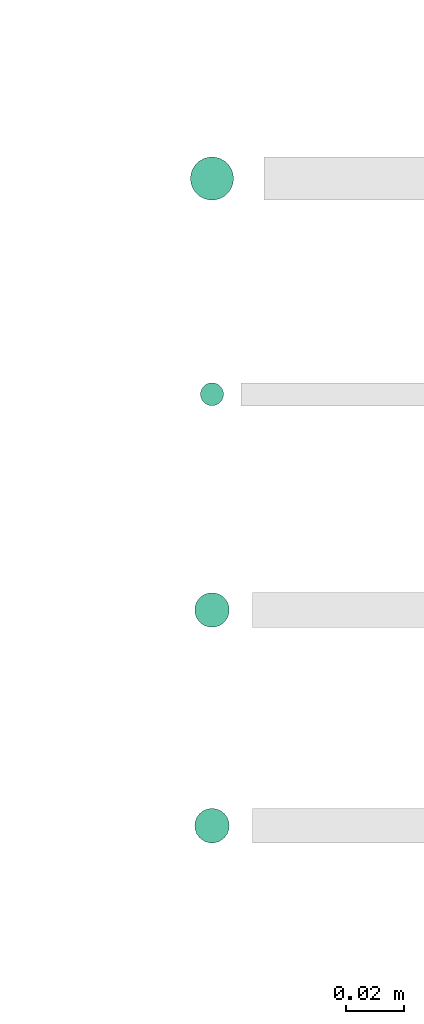
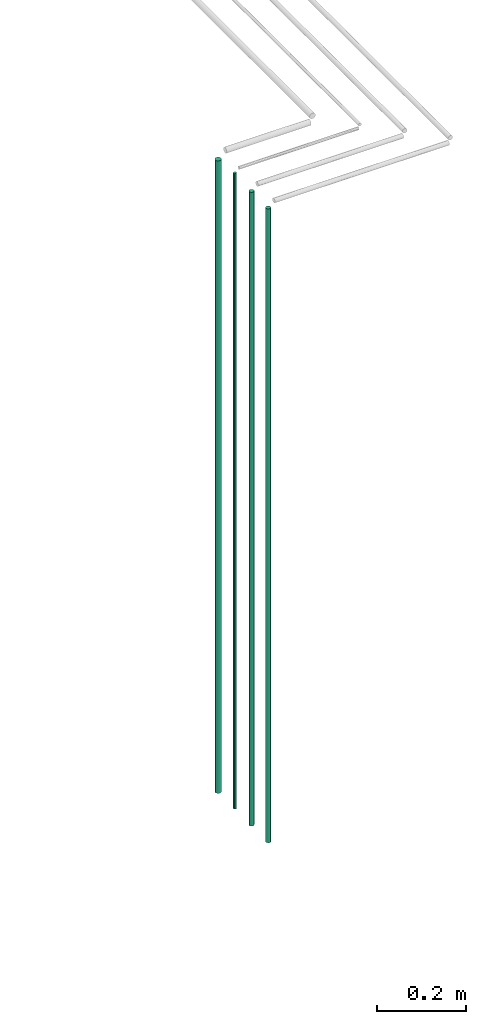
# One storey, part 10 of 65: 4 flow segments.
"""IFC2X3 building model written with IfcOpenShell, lengths in millimetres."""

from ifc_helpers import new_model, entity, si_unit, converted_unit, derived_unit, direction, frame, frame_2d, origin, origin_2d_with_axis, place, context, subcontext, project, spatial, circle, extrude, type_object, element, save


model = new_model("IFC2X3")

# Units and contexts
model_context = context("Model", 3, precision=0.01, world=origin(), true_north=direction((6.12303176911189e-17, 1.0)))
body_context = subcontext(model_context, "Body", "Model", "MODEL_VIEW")
ifc_project = project(units=[si_unit("LENGTHUNIT", "METRE", prefix="MILLI"), si_unit("AREAUNIT", "SQUARE_METRE"), si_unit("VOLUMEUNIT", "CUBIC_METRE"), converted_unit("PLANEANGLEUNIT", "DEGREE", entity("IfcRatioMeasure", 0.0174532925199433), si_unit("PLANEANGLEUNIT", "RADIAN"), dimensions=[0, 0, 0, 0, 0, 0, 0]), si_unit("MASSUNIT", "GRAM", prefix="KILO"), derived_unit("MASSDENSITYUNIT", [(si_unit("MASSUNIT", "GRAM", prefix="KILO"), 1), (si_unit("LENGTHUNIT", "METRE"), -3)]), derived_unit("MOMENTOFINERTIAUNIT", [(si_unit("LENGTHUNIT", "METRE"), 4)]), si_unit("TIMEUNIT", "SECOND"), si_unit("FREQUENCYUNIT", "HERTZ"), si_unit("THERMODYNAMICTEMPERATUREUNIT", "DEGREE_CELSIUS"), derived_unit("THERMALTRANSMITTANCEUNIT", [(si_unit("MASSUNIT", "GRAM", prefix="KILO"), 1), (si_unit("THERMODYNAMICTEMPERATUREUNIT", "KELVIN"), -1), (si_unit("TIMEUNIT", "SECOND"), -3)]), derived_unit("VOLUMETRICFLOWRATEUNIT", [(si_unit("LENGTHUNIT", "METRE"), 3), (si_unit("TIMEUNIT", "SECOND"), -1)]), derived_unit("MASSFLOWRATEUNIT", [(si_unit("MASSUNIT", "GRAM", prefix="KILO"), 1), (si_unit("TIMEUNIT", "SECOND"), -1)]), derived_unit("ROTATIONALFREQUENCYUNIT", [(si_unit("TIMEUNIT", "SECOND"), -1)]), si_unit("ELECTRICCURRENTUNIT", "AMPERE"), si_unit("ELECTRICVOLTAGEUNIT", "VOLT"), si_unit("POWERUNIT", "WATT"), si_unit("FORCEUNIT", "NEWTON", prefix="KILO"), si_unit("ILLUMINANCEUNIT", "LUX"), si_unit("LUMINOUSFLUXUNIT", "LUMEN"), si_unit("LUMINOUSINTENSITYUNIT", "CANDELA"), derived_unit("USERDEFINED", [(si_unit("MASSUNIT", "GRAM", prefix="KILO"), -1), (si_unit("LENGTHUNIT", "METRE"), -2), (si_unit("TIMEUNIT", "SECOND"), 3), (si_unit("LUMINOUSFLUXUNIT", "LUMEN"), 1)]), derived_unit("LINEARVELOCITYUNIT", [(si_unit("LENGTHUNIT", "METRE"), 1), (si_unit("TIMEUNIT", "SECOND"), -1)]), si_unit("PRESSUREUNIT", "PASCAL"), derived_unit("USERDEFINED", [(si_unit("LENGTHUNIT", "METRE"), -2), (si_unit("MASSUNIT", "GRAM", prefix="KILO"), 1), (si_unit("TIMEUNIT", "SECOND"), -2)]), derived_unit("LINEARFORCEUNIT", [(si_unit("MASSUNIT", "GRAM", prefix="KILO"), 1), (si_unit("LENGTHUNIT", "METRE"), 1), (si_unit("TIMEUNIT", "SECOND"), -2), (si_unit("LENGTHUNIT", "METRE"), -1)]), derived_unit("PLANARFORCEUNIT", [(si_unit("MASSUNIT", "GRAM", prefix="KILO"), 1), (si_unit("LENGTHUNIT", "METRE"), 1), (si_unit("TIMEUNIT", "SECOND"), -2), (si_unit("LENGTHUNIT", "METRE"), -2)])], contexts=[model_context])

# Site, building, storey
site_placement = place(None, frame((0.0, -0.00077364408347762, 0.0)))
site = spatial("IfcSite", under=ifc_project, at=site_placement, CompositionType="ELEMENT")
building_placement = place(site_placement, origin())
building = spatial("IfcBuilding", under=site, at=building_placement, CompositionType="ELEMENT")
storey_placement = place(building_placement, frame((0.0, 0.0, 19800.0)))
storey = spatial("IfcBuildingStorey", under=building, at=storey_placement, CompositionType="ELEMENT", Elevation=19800.0)

# Flow segments
pipe_segment_type = type_object("IfcPipeSegmentType", PredefinedType="NOTDEFINED")
flow_segment_1_placement = place(storey_placement, frame((56222.1907684815, 929.499057399854, 1400.0)))
element("IfcFlowSegment", 1, at=flow_segment_1_placement, inside=storey, type_object=pipe_segment_type, context=body_context, shape_type="SweptSolid", body=[
    extrude(circle(Radius=7.5, at=frame_2d((0.0, -1.35358391162299e-13), x_axis=(1.0, 0.0))), frame((9.09527223591419, 9.09527223591622, 0.0)), (0.0, 0.0, 1.0), 1732.0),
])
flow_segment_2_placement = place(storey_placement, frame((56225.6907684815, 857.999057399854, 1400.0)))
element("IfcFlowSegment", 2, at=flow_segment_2_placement, inside=storey, type_object=pipe_segment_type, context=body_context, shape_type="SweptSolid", body=[
    extrude(circle(Radius=4.0, at=origin_2d_with_axis()), frame((5.59527223591499, 5.59527223591607, 0.0)), (0.0, 0.0, 1.0), 1739.99999999999),
])
for number, where in (
    (3, (56223.6907684815, 780.999057399854, 1400.0)),
    (4, (56223.6907684815, 705.999057399854, 1400.0)),
):
    element("IfcFlowSegment", number, at=place(storey_placement, frame(where)), inside=storey, type_object=pipe_segment_type, context=body_context, shape_type="SweptSolid", body=[
        extrude(circle(Radius=6.0, at=origin_2d_with_axis()), frame((7.59527223591454, 7.59527223591603, 0.0)), (0.0, 0.0, 1.0), 1736.0),
    ])

save(model, "model.ifc")
